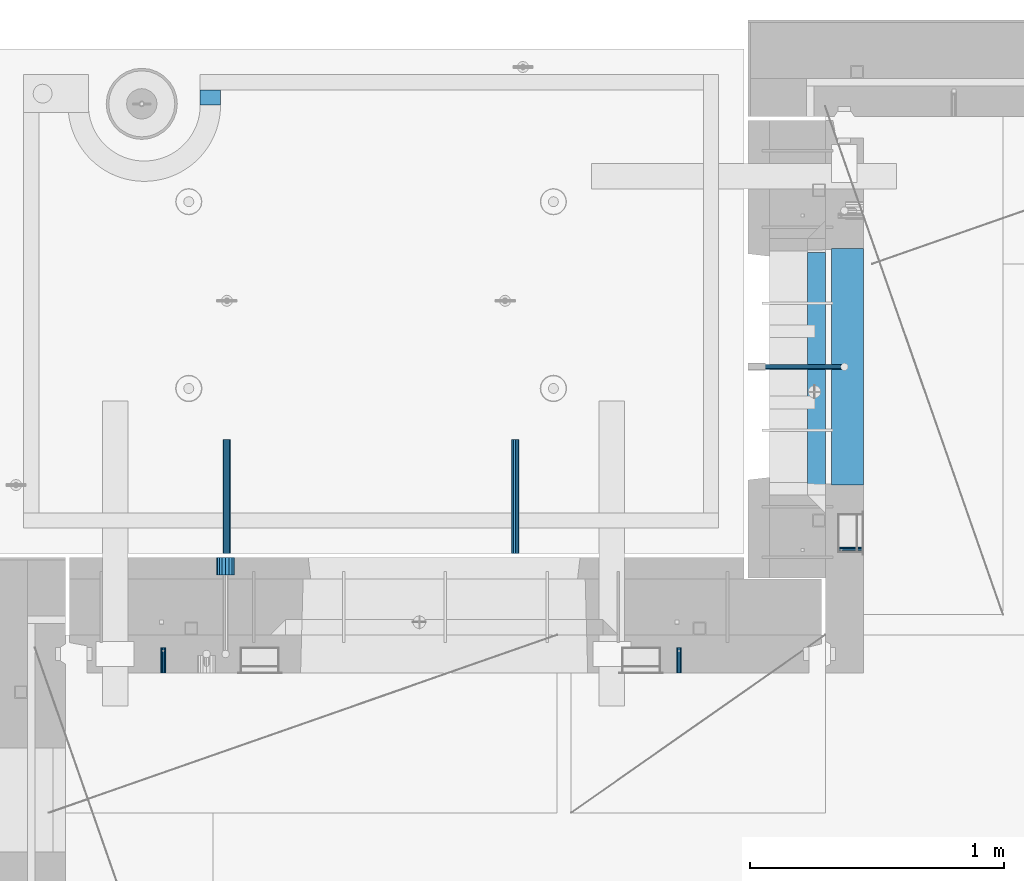
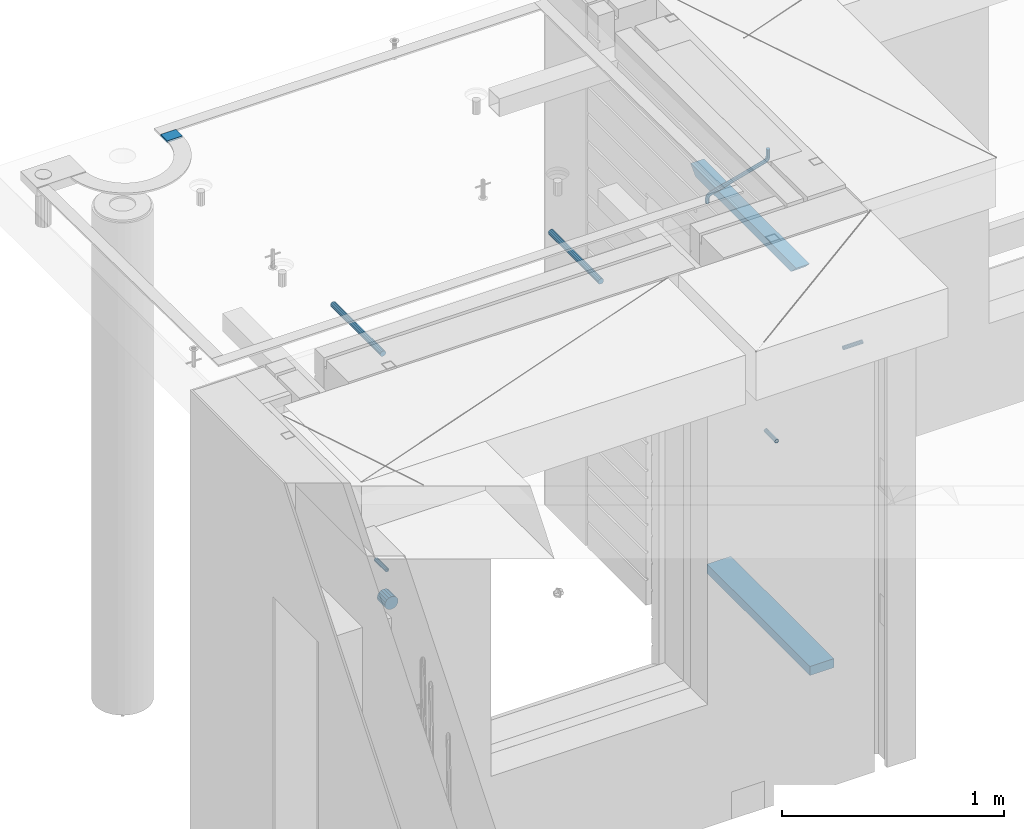
# One storey, part 156 of 352: 10 beams, 8 elements without a shape of their own.
"""IFC2X3 building model written with IfcOpenShell, lengths in millimetres."""

from ifc_helpers import new_model, si_unit, frame, origin_with_axes, place, context, subcontext, project, spatial, faceted_brep, material, type_object, element, aggregate, save


model = new_model("IFC2X3")

# Units and contexts
model_context = context("Model", 3, precision=1e-05, world=origin_with_axes())
body_context = subcontext(model_context, "Body", "Model", "MODEL_VIEW")
ifc_project = project(units=[si_unit("LENGTHUNIT", "METRE", prefix="MILLI"), si_unit("AREAUNIT", "SQUARE_METRE"), si_unit("VOLUMEUNIT", "CUBIC_METRE"), si_unit("MASSUNIT", "GRAM", prefix="KILO"), si_unit("TIMEUNIT", "SECOND"), si_unit("PLANEANGLEUNIT", "RADIAN"), si_unit("SOLIDANGLEUNIT", "STERADIAN"), si_unit("THERMODYNAMICTEMPERATUREUNIT", "DEGREE_CELSIUS"), si_unit("LUMINOUSINTENSITYUNIT", "LUMEN")], contexts=[model_context])

# Site, building, storey
site_placement = place(None, origin_with_axes())
site = spatial("IfcSite", under=ifc_project, at=site_placement, CompositionType="ELEMENT")
building_placement = place(site_placement, origin_with_axes())
building = spatial("IfcBuilding", under=site, at=building_placement, CompositionType="ELEMENT")
storey_placement = place(building_placement, origin_with_axes())
storey = spatial("IfcBuildingStorey", under=building, at=storey_placement, Name="6", CompositionType="ELEMENT", Elevation=0.0)

# Assembly, beam
assembly_1_placement = place(storey_placement, origin_with_axes())
assembly_1 = element("IfcElementAssembly", 1, at=assembly_1_placement, inside=storey, AssemblyPlace="NOTDEFINED", PredefinedType="REINFORCEMENT_UNIT")
ifc_material_1 = material(Name="CONCRETE/C25/30")
beam_type_1 = type_object("IfcBeamType", PredefinedType="NOTDEFINED")
beam_1_placement = place(assembly_1_placement, frame((10955.0, 22139.9998901814, 99080.0), z_axis=(0.0, 0.0, -1.0), x_axis=(0.0, -1.0, 0.0)))
beam_1 = element("IfcBeam", 2, at=beam_1_placement, type_object=beam_type_1, material=ifc_material_1, Name="SK", context=body_context, shape_type="Brep", body=[
    faceted_brep([(100.641025641038, 35.0, 20.6410256410309), (55.0, 35.0, -25.0), (55.0, -35.0, -25.0), (98.8461538461561, -35.0, 18.8461538461561), (966.153464684117, -35.0, 18.8461538461561), (964.358592889246, 35.0, 20.6410256410309), (1009.99961853027, 35.0, -25.0), (1009.99961853027, -35.0, -25.0)], [[[0, 1, 2, 3]], [[0, 3, 4, 5]], [[1, 0, 5, 6]], [[2, 1, 6, 7]], [[3, 2, 7, 4]], [[4, 7, 6, 5]]]),
])

# Assemblies, beams
assembly_2_placement = place(storey_placement, origin_with_axes())
assembly_2 = element("IfcElementAssembly", 3, at=assembly_2_placement, inside=storey, AssemblyPlace="NOTDEFINED", PredefinedType="REINFORCEMENT_UNIT")
assembly_3_placement = place(assembly_2_placement, origin_with_axes())
assembly_3 = element("IfcElementAssembly", 4, at=assembly_3_placement, Name="Steel Assembly", AssemblyPlace="NOTDEFINED", PredefinedType="RIGID_FRAME")
ifc_material_2 = material(Name="STEEL/Steel_Undefined")
beam_type_2 = type_object("IfcBeamType", PredefinedType="NOTDEFINED")
beam_2_placement = place(assembly_3_placement, frame((8384.50481277243, 20430.0, 98754.84), z_axis=(-1.0, 3.00000001838171e-08, 0.0), x_axis=(0.0, 1.0, 0.0)))
beam_2 = element("IfcBeam", 5, at=beam_2_placement, type_object=beam_type_2, material=ifc_material_2, context=body_context, shape_type="Brep", body=[
    faceted_brep([(0.0, -8.49999999999272, -1.45519152283669e-11), (0.0, -7.36121593215648, 4.24999999998545), (100.000000000262, -7.36121593215648, 4.24999999998545), (100.000000000262, -8.49999999999272, -1.45519152283669e-11), (0.0, -4.24999999998545, 7.36121593216376), (100.000000000262, -4.24999999998545, 7.36121593216376), (0.0, 1.45519152283669e-11, 8.49999999998545), (100.000000000262, 1.45519152283669e-11, 8.49999999998545), (0.0, 4.25000000001455, 7.36121593216376), (100.000000000262, 4.25000000001455, 7.36121593216376), (0.0, 7.36121593217104, 4.24999999998545), (100.000000000262, 7.36121593217104, 4.24999999998545), (0.0, 8.50000000000728, 0.0), (100.000000000262, 8.50000000000728, 0.0), (0.0, 7.36121593217104, -4.25000000001455), (100.000000000262, 7.36121593217104, -4.25000000001455), (0.0, 4.25000000000728, -7.36121593219286), (100.000000000262, 4.25000000000728, -7.36121593219286), (0.0, 7.27595761418343e-12, -8.5), (100.000000000262, 7.27595761418343e-12, -8.5), (0.0, -4.24999999999272, -7.36121593217831), (100.000000000262, -4.24999999999272, -7.36121593217831), (0.0, -7.36121593215648, -4.25), (100.000000000262, -7.36121593215648, -4.25), (0.0, -10.4999999999927, -1.45519152283669e-11), (0.0, -9.09326673972828, -5.25000000001455), (100.000000000262, -9.09326673972828, -5.25000000001455), (100.000000000262, -10.4999999999927, -1.45519152283669e-11), (0.0, -5.24999999998545, -9.09326673974283), (100.000000000262, -5.24999999998545, -9.09326673974283), (0.0, 7.27595761418343e-12, -10.5), (100.000000000262, 7.27595761418343e-12, -10.5), (0.0, 5.25000000001455, -9.09326673975738), (100.000000000262, 5.25000000001455, -9.09326673975738), (0.0, 9.09326673975011, -5.25000000001455), (100.000000000262, 9.09326673975011, -5.25000000001455), (0.0, 10.5000000000073, -1.45519152283669e-11), (100.000000000262, 10.5000000000073, -1.45519152283669e-11), (0.0, 9.09326673975011, 5.25), (100.000000000262, 9.09326673975011, 5.25), (0.0, 5.25000000000728, 9.09326673972828), (100.000000000262, 5.25000000000728, 9.09326673972828), (0.0, 1.45519152283669e-11, 10.4999999999854), (100.000000000262, 1.45519152283669e-11, 10.4999999999854), (0.0, -5.24999999999272, 9.09326673972828), (100.000000000262, -5.24999999999272, 9.09326673972828), (0.0, -9.09326673972828, 5.24999999998545), (100.000000000262, -9.09326673972828, 5.24999999998545)], [[[0, 1, 2, 3]], [[1, 4, 5, 2]], [[4, 6, 7, 5]], [[6, 8, 9, 7]], [[8, 10, 11, 9]], [[10, 12, 13, 11]], [[12, 14, 15, 13]], [[14, 16, 17, 15]], [[16, 18, 19, 17]], [[18, 20, 21, 19]], [[20, 22, 23, 21]], [[22, 0, 3, 23]], [[24, 25, 26, 27]], [[25, 28, 29, 26]], [[28, 30, 31, 29]], [[30, 32, 33, 31]], [[32, 34, 35, 33]], [[34, 36, 37, 35]], [[36, 38, 39, 37]], [[38, 40, 41, 39]], [[40, 42, 43, 41]], [[42, 44, 45, 43]], [[44, 46, 47, 45]], [[46, 24, 27, 47]], [[29, 31, 33, 35, 37, 39, 41, 43, 45, 47, 27, 26], [5, 7, 9, 11, 13, 15, 17, 19, 21, 23, 3, 2]], [[46, 44, 42, 40, 38, 36, 34, 32, 30, 28, 25, 24], [22, 20, 18, 16, 14, 12, 10, 8, 6, 4, 1, 0]]]),
])
aggregate(assembly_3, [beam_2])
assembly_4_placement = place(assembly_2_placement, origin_with_axes())
assembly_4 = element("IfcElementAssembly", 6, at=assembly_4_placement, Name="Steel Assembly", AssemblyPlace="NOTDEFINED", PredefinedType="RIGID_FRAME")
beam_3_placement = place(assembly_4_placement, frame((10414.5048127724, 20430.0, 98754.84), z_axis=(-1.0, 3.00000001838171e-08, 0.0), x_axis=(0.0, 1.0, 0.0)))
beam_3 = element("IfcBeam", 7, at=beam_3_placement, type_object=beam_type_2, material=ifc_material_2, context=body_context, shape_type="Brep", body=[
    faceted_brep([(0.0, -8.49999999999272, -1.45519152283669e-11), (0.0, -7.36121593215648, 4.24999999998545), (100.000000000262, -7.36121593215648, 4.24999999998545), (100.000000000262, -8.49999999999272, -1.45519152283669e-11), (0.0, -4.24999999998545, 7.36121593216376), (100.000000000262, -4.24999999998545, 7.36121593216376), (0.0, 1.45519152283669e-11, 8.49999999998545), (100.000000000262, 1.45519152283669e-11, 8.49999999998545), (0.0, 4.25000000001455, 7.36121593216376), (100.000000000262, 4.25000000001455, 7.36121593216376), (0.0, 7.36121593217104, 4.24999999998545), (100.000000000262, 7.36121593217104, 4.24999999998545), (0.0, 8.50000000000728, 0.0), (100.000000000262, 8.50000000000728, 0.0), (0.0, 7.36121593217104, -4.25000000001455), (100.000000000262, 7.36121593217104, -4.25000000001455), (0.0, 4.25000000000728, -7.36121593219286), (100.000000000262, 4.25000000000728, -7.36121593219286), (0.0, 7.27595761418343e-12, -8.5), (100.000000000262, 7.27595761418343e-12, -8.5), (0.0, -4.24999999999272, -7.36121593217831), (100.000000000262, -4.24999999999272, -7.36121593217831), (0.0, -7.36121593215648, -4.25), (100.000000000262, -7.36121593215648, -4.25), (0.0, -10.4999999999927, -1.45519152283669e-11), (0.0, -9.09326673972828, -5.25000000001455), (100.000000000262, -9.09326673972828, -5.25000000001455), (100.000000000262, -10.4999999999927, -1.45519152283669e-11), (0.0, -5.24999999998545, -9.09326673974283), (100.000000000262, -5.24999999998545, -9.09326673974283), (0.0, 7.27595761418343e-12, -10.5), (100.000000000262, 7.27595761418343e-12, -10.5), (0.0, 5.25000000001455, -9.09326673975738), (100.000000000262, 5.25000000001455, -9.09326673975738), (0.0, 9.09326673975011, -5.25000000001455), (100.000000000262, 9.09326673975011, -5.25000000001455), (0.0, 10.5000000000073, -1.45519152283669e-11), (100.000000000262, 10.5000000000073, -1.45519152283669e-11), (0.0, 9.09326673975011, 5.25), (100.000000000262, 9.09326673975011, 5.25), (0.0, 5.25000000000728, 9.09326673972828), (100.000000000262, 5.25000000000728, 9.09326673972828), (0.0, 1.45519152283669e-11, 10.4999999999854), (100.000000000262, 1.45519152283669e-11, 10.4999999999854), (0.0, -5.24999999999272, 9.09326673972828), (100.000000000262, -5.24999999999272, 9.09326673972828), (0.0, -9.09326673972828, 5.24999999998545), (100.000000000262, -9.09326673972828, 5.24999999998545)], [[[0, 1, 2, 3]], [[1, 4, 5, 2]], [[4, 6, 7, 5]], [[6, 8, 9, 7]], [[8, 10, 11, 9]], [[10, 12, 13, 11]], [[12, 14, 15, 13]], [[14, 16, 17, 15]], [[16, 18, 19, 17]], [[18, 20, 21, 19]], [[20, 22, 23, 21]], [[22, 0, 3, 23]], [[24, 25, 26, 27]], [[25, 28, 29, 26]], [[28, 30, 31, 29]], [[30, 32, 33, 31]], [[32, 34, 35, 33]], [[34, 36, 37, 35]], [[36, 38, 39, 37]], [[38, 40, 41, 39]], [[40, 42, 43, 41]], [[42, 44, 45, 43]], [[44, 46, 47, 45]], [[46, 24, 27, 47]], [[29, 31, 33, 35, 37, 39, 41, 43, 45, 47, 27, 26], [5, 7, 9, 11, 13, 15, 17, 19, 21, 23, 3, 2]], [[46, 44, 42, 40, 38, 36, 34, 32, 30, 28, 25, 24], [22, 20, 18, 16, 14, 12, 10, 8, 6, 4, 1, 0]]]),
])
aggregate(assembly_4, [beam_3])

# Assembly, beam
assembly_5_placement = place(assembly_1_placement, origin_with_axes())
assembly_5 = element("IfcElementAssembly", 8, at=assembly_5_placement, Name="Steel Assembly", AssemblyPlace="NOTDEFINED", PredefinedType="RIGID_FRAME")
beam_4_placement = place(assembly_5_placement, frame((11140.0, 20914.9954408996, 98755.0), z_axis=(0.0, -1.0, 0.0), x_axis=(-1.0, 3.00000001838171e-08, 0.0)))
beam_4 = element("IfcBeam", 9, at=beam_4_placement, type_object=beam_type_2, material=ifc_material_2, Name="M16", context=body_context, shape_type="Brep", body=[
    faceted_brep([(0.0, -8.49999999999272, -1.45519152283669e-11), (0.0, -7.36121593215648, 4.24999999998545), (100.000000000262, -7.36121593215648, 4.24999999998545), (100.000000000262, -8.49999999999272, -1.45519152283669e-11), (0.0, -4.24999999998545, 7.36121593216376), (100.000000000262, -4.24999999998545, 7.36121593216376), (0.0, 1.45519152283669e-11, 8.49999999998545), (100.000000000262, 1.45519152283669e-11, 8.49999999998545), (0.0, 4.25000000001455, 7.36121593216376), (100.000000000262, 4.25000000001455, 7.36121593216376), (0.0, 7.36121593217104, 4.24999999998545), (100.000000000262, 7.36121593217104, 4.24999999998545), (0.0, 8.50000000000728, 0.0), (100.000000000262, 8.50000000000728, 0.0), (0.0, 7.36121593217104, -4.25000000001455), (100.000000000262, 7.36121593217104, -4.25000000001455), (0.0, 4.25000000000728, -7.36121593219286), (100.000000000262, 4.25000000000728, -7.36121593219286), (0.0, 7.27595761418343e-12, -8.5), (100.000000000262, 7.27595761418343e-12, -8.5), (0.0, -4.24999999999272, -7.36121593217831), (100.000000000262, -4.24999999999272, -7.36121593217831), (0.0, -7.36121593215648, -4.25), (100.000000000262, -7.36121593215648, -4.25), (0.0, -10.4999999999927, -1.45519152283669e-11), (0.0, -9.09326673972828, -5.25000000001455), (100.000000000262, -9.09326673972828, -5.25000000001455), (100.000000000262, -10.4999999999927, -1.45519152283669e-11), (0.0, -5.24999999998545, -9.09326673974283), (100.000000000262, -5.24999999998545, -9.09326673974283), (0.0, 7.27595761418343e-12, -10.5), (100.000000000262, 7.27595761418343e-12, -10.5), (0.0, 5.25000000001455, -9.09326673975738), (100.000000000262, 5.25000000001455, -9.09326673975738), (0.0, 9.09326673975011, -5.25000000001455), (100.000000000262, 9.09326673975011, -5.25000000001455), (0.0, 10.5000000000073, -1.45519152283669e-11), (100.000000000262, 10.5000000000073, -1.45519152283669e-11), (0.0, 9.09326673975011, 5.25), (100.000000000262, 9.09326673975011, 5.25), (0.0, 5.25000000000728, 9.09326673972828), (100.000000000262, 5.25000000000728, 9.09326673972828), (0.0, 1.45519152283669e-11, 10.4999999999854), (100.000000000262, 1.45519152283669e-11, 10.4999999999854), (0.0, -5.24999999999272, 9.09326673972828), (100.000000000262, -5.24999999999272, 9.09326673972828), (0.0, -9.09326673972828, 5.24999999998545), (100.000000000262, -9.09326673972828, 5.24999999998545)], [[[0, 1, 2, 3]], [[1, 4, 5, 2]], [[4, 6, 7, 5]], [[6, 8, 9, 7]], [[8, 10, 11, 9]], [[10, 12, 13, 11]], [[12, 14, 15, 13]], [[14, 16, 17, 15]], [[16, 18, 19, 17]], [[18, 20, 21, 19]], [[20, 22, 23, 21]], [[22, 0, 3, 23]], [[24, 25, 26, 27]], [[25, 28, 29, 26]], [[28, 30, 31, 29]], [[30, 32, 33, 31]], [[32, 34, 35, 33]], [[34, 36, 37, 35]], [[36, 38, 39, 37]], [[38, 40, 41, 39]], [[40, 42, 43, 41]], [[42, 44, 45, 43]], [[44, 46, 47, 45]], [[46, 24, 27, 47]], [[29, 31, 33, 35, 37, 39, 41, 43, 45, 47, 27, 26], [5, 7, 9, 11, 13, 15, 17, 19, 21, 23, 3, 2]], [[46, 44, 42, 40, 38, 36, 34, 32, 30, 28, 25, 24], [22, 20, 18, 16, 14, 12, 10, 8, 6, 4, 1, 0]]]),
])
aggregate(assembly_5, [beam_4])

# Beam
ifc_material_3 = material()
beam_type_3 = type_object("IfcBeamType", Name="D20", PredefinedType="NOTDEFINED")
beam_5_placement = place(assembly_1_placement, frame((10747.93, 21634.9982799665, 99220.28), z_axis=(0.999209485784166, 0.00020572799995638, -0.0397537569914116), x_axis=(0.0397537569984931, -6.39999925638531e-08, 0.999209506962629)))
beam_5 = element("IfcBeam", 10, at=beam_5_placement, type_object=beam_type_3, material=ifc_material_3, Name="JM20", ObjectType="D20", context=body_context, shape_type="Brep", body=[
    faceted_brep([(0.0, -10.0, 0.0), (-4.19531716033816e-08, -7.07106781186667, -7.07106781187031), (26.3851730625611, -7.07106780271351, -7.07106779974674), (26.3851730660535, -9.99999999077045, 1.18243406177498e-08), (0.0, 0.0, -10.0), (26.3851730589668, 9.14587872102857e-09, -9.99999998788189), (4.196772351861e-08, 7.07106781186303, -7.07106781186667), (26.3851730576571, 7.07106782101255, -7.0710677997472), (0.0, 10.0, 0.0), (26.3851730593888, 10.0000000091495, 1.21176526590716e-08), (4.196772351861e-08, 7.07106781185939, 7.07106781185939), (26.3851730631723, 7.07106782101619, 7.07106782398387), (0.0, 0.0, 10.0), (26.3851730667375, 9.15315467864275e-09, 10.0000000121181), (-4.19531716033816e-08, -7.07106781187031, 7.07106781185939), (26.3851730680617, -7.07106780271351, 7.07106782398296), (38.6387990555377, 0.00053833780111745, -7.38336449283906), (37.4430586178205, -7.07058200552274, -4.70977034770021), (34.5550974405633, -9.99964106806146, 1.74460312923975), (31.6666440137633, -7.07083577596131, 8.19887149183023), (30.4697151806322, 0.000179452214069897, 10.8722118684241), (31.6654556183639, 7.07129979554884, 8.19861772327886), (34.5534167956066, 10.0003588580803, 1.74424424634026), (37.4418702223775, 7.07155356597286, -4.71002411625204), (46.5698109210789, 7.07292605872499, 1.96124086770624), (48.7548734831362, 0.00205940803425619, 0.0100898832683924), (41.2967727296491, 10.0013728005906, 6.67270684289633), (36.0246331664675, 7.07195524891722, 11.3845749391899), (33.8417400848848, 0.000686475628754124, 13.3366967298962), (36.0268026468402, -7.07018017507653, 11.385545745416), (41.2998408382991, -9.99862691692761, 6.67407977023777), (46.5719804015243, -7.06920936526149, 1.96221167398289), (52.1766955363273, 7.07494587836845, 11.77897587077), (54.9687243336812, 0.00429788071051007, 10.8906314292522), (45.4389138642146, 10.0028649622, 13.9256551011317), (38.7022804405424, 7.07291984242329, 16.0731735411446), (35.9130237601494, 0.00143263318750542, 16.9635440140905), (38.7050525575032, -7.06921536447044, 16.0751995724927), (45.4428342298197, -9.99713444846202, 13.9285203429881), (52.1794676532882, -7.06718932852891, 11.7810019021831), (142.166420299589, -7.00909836739083, 294.143799597011), (135.429786872017, -9.93904348683645, 296.291318034092), (144.955676979953, 0.0623888418631395, 293.253429124143), (142.163648182657, 7.13303683951744, 294.141773565681), (135.425866510661, 10.0609559233271, 296.288452795829), (128.689233087061, 7.13101080351771, 298.435971235634), (125.899976406712, 0.0595235942673753, 299.326341708503), (128.692005203993, -7.01112440339057, 298.437997266966), (147.068569920637, 0.0631443010061048, 296.926548661886), (144.897857494318, -7.00812174957537, 298.892215917644), (139.655137467547, -9.93753272500544, 303.636800386314), (134.411524128242, -7.00907940566321, 308.380988833921), (132.238655054738, 0.0617899707685865, 310.345700010335), (134.409367481101, 7.13305602133914, 308.38003275464), (139.652087507944, 10.0624669967765, 303.63544828606), (144.895700847192, 7.13401367743427, 298.891259838389), (149.349355837621, 7.13466950711154, 302.082919188319), (150.512901837996, 0.0636515012993186, 299.394888529177), (146.541460642286, 10.0634815017911, 308.572636332), (143.734043175544, 7.13442914049301, 315.062451673432), (142.571650514263, 0.0633115715718304, 317.750719402909), (143.735196514695, -7.0077064342513, 315.062688743805), (146.543091710148, -9.93651842893087, 308.572971600169), (149.350509176773, -7.0074660676255, 302.083156258706), (154.724909358454, 7.13488656737172, 303.143653317829), (154.670204234542, 0.063819369621342, 300.215230568659), (154.856921558763, 10.0638172729959, 310.213489346082), (154.988909878753, 7.13488360238989, 317.283324591871), (155.043557350815, 0.0638151764978829, 320.211745451903), (154.988852227005, -7.00725202125614, 317.28332270274), (154.856840031658, -9.93618272723688, 310.213486674455), (154.724851706691, -7.00724905626703, 303.143651428684), (199.544700311235, -7.00743165723543, 302.30682413155), (199.676688632229, -9.93636532781238, 309.37665937721), (199.490052838737, 0.0636367686238373, 299.378403271518), (199.544757962984, 7.13470396637786, 302.306826020583), (199.676770164122, 10.0636346720203, 309.376662048705), (199.808758485131, 7.13470100144696, 316.446497294365), (199.863405957614, 0.0636325755804137, 319.374918154397), (199.808700833368, -7.00743462216269, 316.446495405334)], [[[0, 1, 2, 3]], [[1, 4, 5, 2]], [[4, 6, 7, 5]], [[6, 8, 9, 7]], [[8, 10, 11, 9]], [[10, 12, 13, 11]], [[12, 14, 15, 13]], [[14, 0, 3, 15]], [[14, 12, 10, 8, 6, 4, 1, 0]], [[2, 5, 16, 17]], [[3, 2, 17, 18]], [[15, 3, 18, 19]], [[13, 15, 19, 20]], [[11, 13, 20, 21]], [[9, 11, 21, 22]], [[7, 9, 22, 23]], [[5, 7, 23, 16]], [[23, 24, 25, 16]], [[22, 26, 24, 23]], [[21, 27, 26, 22]], [[20, 28, 27, 21]], [[19, 29, 28, 20]], [[18, 30, 29, 19]], [[17, 31, 30, 18]], [[16, 25, 31, 17]], [[24, 32, 33, 25]], [[26, 34, 32, 24]], [[27, 35, 34, 26]], [[28, 36, 35, 27]], [[29, 37, 36, 28]], [[30, 38, 37, 29]], [[31, 39, 38, 30]], [[25, 33, 39, 31]], [[38, 39, 40, 41]], [[39, 33, 42, 40]], [[33, 32, 43, 42]], [[32, 34, 44, 43]], [[34, 35, 45, 44]], [[35, 36, 46, 45]], [[36, 37, 47, 46]], [[37, 38, 41, 47]], [[40, 42, 48, 49]], [[41, 40, 49, 50]], [[47, 41, 50, 51]], [[46, 47, 51, 52]], [[45, 46, 52, 53]], [[44, 45, 53, 54]], [[43, 44, 54, 55]], [[42, 43, 55, 48]], [[55, 56, 57, 48]], [[54, 58, 56, 55]], [[53, 59, 58, 54]], [[52, 60, 59, 53]], [[51, 61, 60, 52]], [[50, 62, 61, 51]], [[49, 63, 62, 50]], [[48, 57, 63, 49]], [[56, 64, 65, 57]], [[58, 66, 64, 56]], [[59, 67, 66, 58]], [[60, 68, 67, 59]], [[61, 69, 68, 60]], [[62, 70, 69, 61]], [[63, 71, 70, 62]], [[57, 65, 71, 63]], [[70, 71, 72, 73]], [[71, 65, 74, 72]], [[65, 64, 75, 74]], [[64, 66, 76, 75]], [[66, 67, 77, 76]], [[67, 68, 78, 77]], [[68, 69, 79, 78]], [[69, 70, 73, 79]], [[74, 75, 76, 77, 78, 79, 73, 72]]]),
])

beam_type_4 = type_object("IfcBeamType", Name="D70", PredefinedType="NOTDEFINED")
beam_6_placement = place(assembly_2_placement, frame((8630.0, 20884.9951872276, 98255.0), z_axis=(0.0, 0.0, 1.0), x_axis=(0.0, -1.0, 0.0)))
beam_6 = element("IfcBeam", 11, at=beam_6_placement, type_object=beam_type_4, material=ifc_material_3, ObjectType="D70", context=body_context, shape_type="Brep", body=[
    faceted_brep([(0.0, -35.0, 0.0), (0.0, -32.3357836378964, -13.3939201327739), (70.0, -32.3357836378964, -13.3939201327739), (70.0, -35.0, 0.0), (0.0, -24.7487373415279, -24.7487373415352), (70.0, -24.7487373415279, -24.7487373415352), (0.0, -13.3939201327776, -32.3357836379), (70.0, -13.3939201327776, -32.3357836379), (0.0, 0.0, -35.0), (70.0, 0.0, -35.0), (0.0, 13.3939201327776, -32.3357836379), (70.0, 13.3939201327776, -32.3357836379), (0.0, 24.7487373415279, -24.7487373415352), (70.0, 24.7487373415279, -24.7487373415352), (0.0, 32.3357836378964, -13.3939201327739), (70.0, 32.3357836378964, -13.3939201327739), (0.0, 35.0, 0.0), (70.0, 35.0, 0.0), (0.0, 32.3357836378964, 13.3939201327739), (70.0, 32.3357836378964, 13.3939201327739), (0.0, 24.7487373415279, 24.7487373415352), (70.0, 24.7487373415279, 24.7487373415352), (0.0, 13.3939201327776, 32.3357836379), (70.0, 13.3939201327776, 32.3357836379), (0.0, 0.0, 35.0), (70.0, 0.0, 35.0), (0.0, -13.3939201327776, 32.3357836379), (70.0, -13.3939201327776, 32.3357836379), (0.0, -24.7487373415279, 24.7487373415352), (70.0, -24.7487373415279, 24.7487373415352), (0.0, -32.3357836378964, 13.3939201327739), (70.0, -32.3357836378964, 13.3939201327739)], [[[0, 1, 2, 3]], [[1, 4, 5, 2]], [[4, 6, 7, 5]], [[6, 8, 9, 7]], [[8, 10, 11, 9]], [[10, 12, 13, 11]], [[12, 14, 15, 13]], [[14, 16, 17, 15]], [[16, 18, 19, 17]], [[18, 20, 21, 19]], [[20, 22, 23, 21]], [[22, 24, 25, 23]], [[24, 26, 27, 25]], [[26, 28, 29, 27]], [[28, 30, 31, 29]], [[30, 0, 3, 31]], [[5, 7, 9, 11, 13, 15, 17, 19, 21, 23, 25, 27, 29, 31, 3, 2]], [[30, 28, 26, 24, 22, 20, 18, 16, 14, 12, 10, 8, 6, 4, 1, 0]]]),
])

aggregate(assembly_2, [beam_6, assembly_3, assembly_4])

ifc_material_4 = material(Name="TIMBER/PUU")
beam_type_5 = type_object("IfcBeamType", PredefinedType="NOTDEFINED")
beam_7_placement = place(assembly_1_placement, frame((11077.5, 21169.9999618525, 96830.0), z_axis=(0.0, 0.0, 1.0), x_axis=(0.0, 1.0, 0.0)))
beam_7 = element("IfcBeam", 12, at=beam_7_placement, type_object=beam_type_5, material=ifc_material_4, context=body_context, shape_type="Brep", body=[
    faceted_brep([(0.0, 62.5, -25.0), (0.0, 62.5, 25.0), (930.0, 62.5, 25.0), (930.0, 62.5, -25.0), (0.0, -62.5, 25.0), (930.0, -62.5, 25.0), (0.0, -62.5, -25.0), (930.0, -62.5, -25.0)], [[[0, 1, 2, 3]], [[1, 4, 5, 2]], [[4, 6, 7, 5]], [[6, 0, 3, 7]], [[5, 7, 3, 2]], [[6, 4, 1, 0]]]),
])

aggregate(assembly_1, [beam_5, assembly_5, beam_7, beam_1])

# Assemblies, beams
assembly_6_placement = place(storey_placement, origin_with_axes())
assembly_6 = element("IfcElementAssembly", 13, at=assembly_6_placement, inside=storey, AssemblyPlace="NOTDEFINED", PredefinedType="REINFORCEMENT_UNIT")
assembly_7_placement = place(assembly_6_placement, origin_with_axes())
assembly_7 = element("IfcElementAssembly", 14, at=assembly_7_placement, Name="Steel Assembly", AssemblyPlace="NOTDEFINED", PredefinedType="RIGID_FRAME")
ifc_material_5 = material(Name="STEEL/S235JR")
beam_type_6 = type_object("IfcBeamType", Name="D30", PredefinedType="NOTDEFINED")
beam_8_placement = place(assembly_7_placement, frame((8634.99985675633, 20900.0253394533, 99575.0), z_axis=(0.0, 0.0, 1.0), x_axis=(0.0, 1.0, 0.0)))
beam_8 = element("IfcBeam", 15, at=beam_8_placement, type_object=beam_type_6, material=ifc_material_5, Name="Rd30", ObjectType="D30", context=body_context, shape_type="Brep", body=[
    faceted_brep([(0.0, -15.0, 0.0), (0.0, -12.9903810567666, -7.5), (450.0, -12.9903810567666, -7.5), (450.0, -15.0, 0.0), (0.0, -7.5, -12.9903810567666), (450.0, -7.5, -12.990381056763), (0.0, 0.0, -15.0), (450.0, 0.0, -15.0), (0.0, 7.5, -12.9903810567666), (450.0, 7.5, -12.990381056763), (0.0, 12.9903810567666, -7.5), (450.0, 12.9903810567666, -7.5), (0.0, 15.0, 0.0), (450.0, 15.0, 0.0), (0.0, 12.9903810567666, 7.5), (450.0, 12.9903810567666, 7.5), (0.0, 7.5, 12.9903810567666), (450.0, 7.5, 12.990381056763), (0.0, 0.0, 15.0), (450.0, 0.0, 15.0), (0.0, -7.5, 12.9903810567666), (450.0, -7.5, 12.990381056763), (0.0, -12.9903810567666, 7.5), (450.0, -12.9903810567666, 7.5)], [[[0, 1, 2, 3]], [[1, 4, 5, 2]], [[4, 6, 7, 5]], [[6, 8, 9, 7]], [[8, 10, 11, 9]], [[10, 12, 13, 11]], [[12, 14, 15, 13]], [[14, 16, 17, 15]], [[16, 18, 19, 17]], [[18, 20, 21, 19]], [[20, 22, 23, 21]], [[22, 0, 3, 23]], [[5, 7, 9, 11, 13, 15, 17, 19, 21, 23, 3, 2]], [[22, 20, 18, 16, 14, 12, 10, 8, 6, 4, 1, 0]]]),
])
aggregate(assembly_7, [beam_8])
assembly_8_placement = place(assembly_6_placement, origin_with_axes())
assembly_8 = element("IfcElementAssembly", 16, at=assembly_8_placement, Name="Steel Assembly", AssemblyPlace="NOTDEFINED", PredefinedType="RIGID_FRAME")
beam_9_placement = place(assembly_8_placement, frame((9769.99985700661, 20900.0152136098, 99575.0), z_axis=(0.0, 0.0, 1.0), x_axis=(0.0, 1.0, 0.0)))
beam_9 = element("IfcBeam", 17, at=beam_9_placement, type_object=beam_type_6, material=ifc_material_5, Name="Rd30", ObjectType="D30", context=body_context, shape_type="Brep", body=[
    faceted_brep([(0.0, -15.0, 0.0), (0.0, -12.9903810567666, -7.5), (450.0, -12.9903810567666, -7.5), (450.0, -15.0, 0.0), (0.0, -7.5, -12.9903810567666), (450.0, -7.5, -12.990381056763), (0.0, 0.0, -15.0), (450.0, 0.0, -15.0), (0.0, 7.5, -12.9903810567666), (450.0, 7.5, -12.990381056763), (0.0, 12.9903810567666, -7.5), (450.0, 12.9903810567666, -7.5), (0.0, 15.0, 0.0), (450.0, 15.0, 0.0), (0.0, 12.9903810567666, 7.5), (450.0, 12.9903810567666, 7.5), (0.0, 7.5, 12.9903810567666), (450.0, 7.5, 12.990381056763), (0.0, 0.0, 15.0), (450.0, 0.0, 15.0), (0.0, -7.5, 12.9903810567666), (450.0, -7.5, 12.990381056763), (0.0, -12.9903810567666, 7.5), (450.0, -12.9903810567666, 7.5)], [[[0, 1, 2, 3]], [[1, 4, 5, 2]], [[4, 6, 7, 5]], [[6, 8, 9, 7]], [[8, 10, 11, 9]], [[10, 12, 13, 11]], [[12, 14, 15, 13]], [[14, 16, 17, 15]], [[16, 18, 19, 17]], [[18, 20, 21, 19]], [[20, 22, 23, 21]], [[22, 0, 3, 23]], [[5, 7, 9, 11, 13, 15, 17, 19, 21, 23, 3, 2]], [[22, 20, 18, 16, 14, 12, 10, 8, 6, 4, 1, 0]]]),
])
aggregate(assembly_8, [beam_9])
ifc_material_6 = material(Name="CONCRETE/Concrete_Undefined")
beam_type_7 = type_object("IfcBeamType", PredefinedType="NOTDEFINED")
beam_10_placement = place(assembly_6_placement, frame((8570.00544375128, 22665.0534145719, 99707.3590237257), z_axis=(1.00999999609277e-07, -0.00299573299934615, 0.999995512781826), x_axis=(-0.000187248000059734, 0.999995495250841, 0.0029957330006511)))
beam_10 = element("IfcBeam", 18, at=beam_10_placement, type_object=beam_type_7, material=ifc_material_6, context=body_context, shape_type="Brep", body=[
    faceted_brep([(1.34605215862393e-10, 40.0, -5.0), (-1.20053300634027e-10, 39.9999999999982, 4.99999999998545), (60.1825564420724, 39.9999999999982, 5.0), (60.182556442418, 40.0, -5.0), (-1.23691279441118e-10, -40.0000000000018, 4.9999999999709), (60.1825564420724, -40.0, 5.0), (1.30967237055302e-10, -40.0, -5.00000000001455), (60.182556442418, -39.9999999999982, -5.0)], [[[0, 1, 2, 3]], [[1, 4, 5, 2]], [[4, 6, 7, 5]], [[6, 0, 3, 7]], [[5, 7, 3, 2]], [[6, 4, 1, 0]]]),
])
aggregate(assembly_6, [assembly_7, assembly_8, beam_10])

save(model, "model.ifc")
